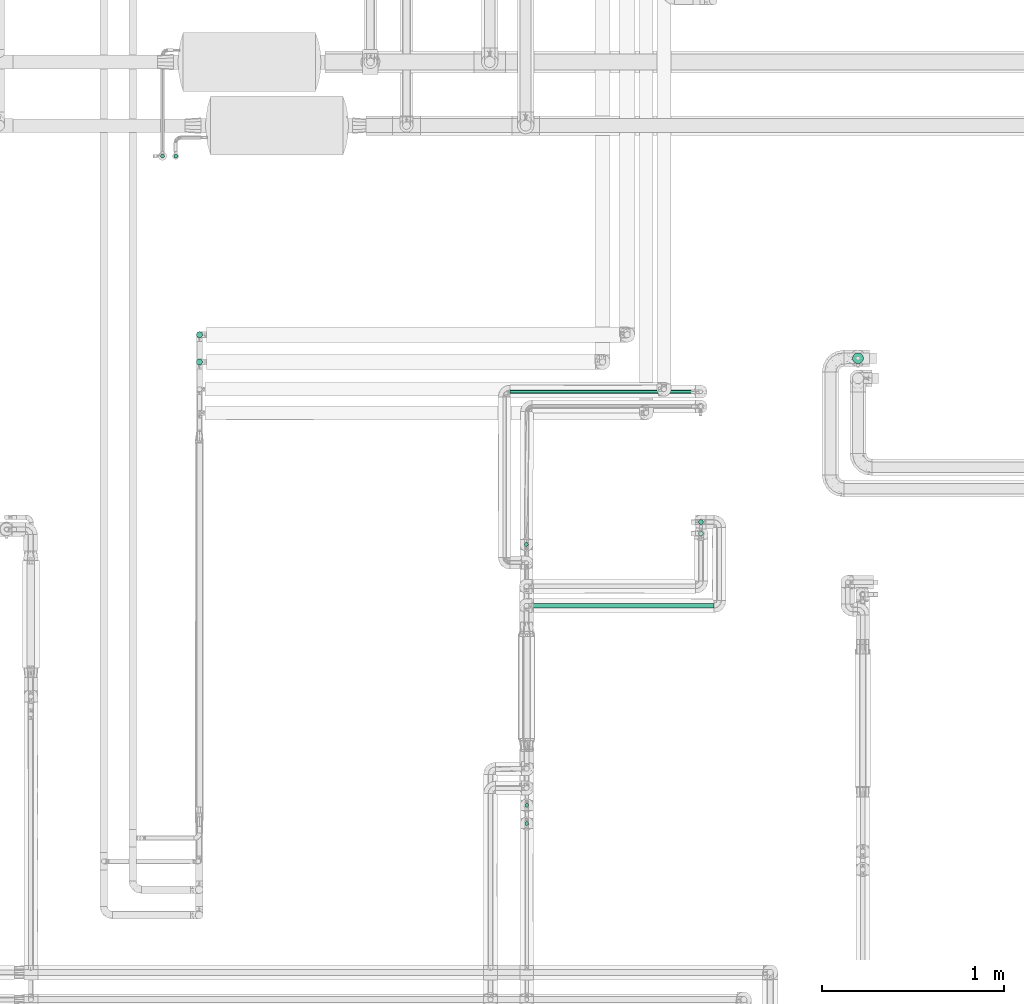
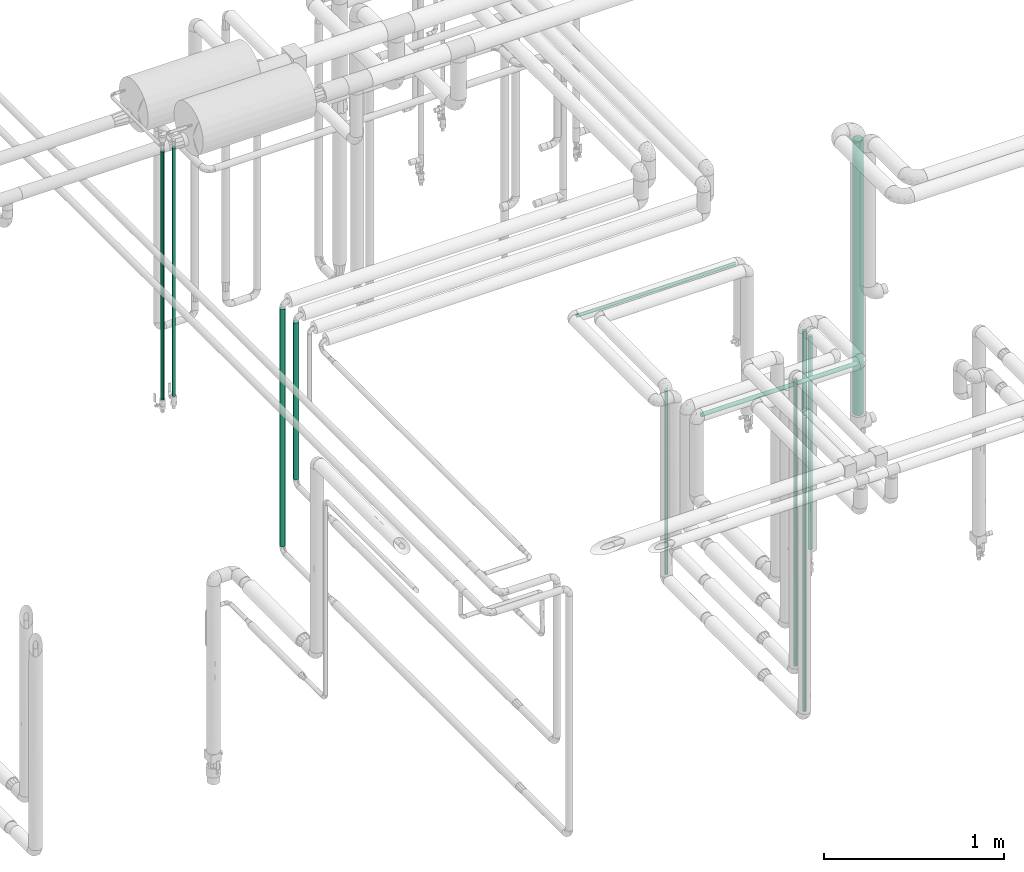
# One storey, part 520 of 827: 12 flow segments.
"""IFC2X3 building model written with IfcOpenShell, lengths in millimetres."""

from ifc_helpers import new_model, entity, si_unit, converted_unit, derived_unit, direction, frame, origin, origin_2d_with_axis, place, context, subcontext, project, spatial, circle, extrude, type_object, element, save


model = new_model("IFC2X3")

# Units and contexts
model_context = context("Model", 3, precision=0.01, world=origin(), true_north=direction((6.12303176911189e-17, 1.0)))
body_context = subcontext(model_context, "Body", "Model", "MODEL_VIEW")
ifc_project = project(units=[si_unit("LENGTHUNIT", "METRE", prefix="MILLI"), si_unit("AREAUNIT", "SQUARE_METRE"), si_unit("VOLUMEUNIT", "CUBIC_METRE"), converted_unit("PLANEANGLEUNIT", "DEGREE", entity("IfcRatioMeasure", 0.0174532925199433), si_unit("PLANEANGLEUNIT", "RADIAN"), dimensions=[0, 0, 0, 0, 0, 0, 0]), si_unit("MASSUNIT", "GRAM", prefix="KILO"), derived_unit("MASSDENSITYUNIT", [(si_unit("MASSUNIT", "GRAM", prefix="KILO"), 1), (si_unit("LENGTHUNIT", "METRE"), -3)]), derived_unit("MOMENTOFINERTIAUNIT", [(si_unit("LENGTHUNIT", "METRE"), 4)]), si_unit("TIMEUNIT", "SECOND"), si_unit("FREQUENCYUNIT", "HERTZ"), si_unit("THERMODYNAMICTEMPERATUREUNIT", "DEGREE_CELSIUS"), derived_unit("THERMALTRANSMITTANCEUNIT", [(si_unit("MASSUNIT", "GRAM", prefix="KILO"), 1), (si_unit("THERMODYNAMICTEMPERATUREUNIT", "KELVIN"), -1), (si_unit("TIMEUNIT", "SECOND"), -3)]), derived_unit("VOLUMETRICFLOWRATEUNIT", [(si_unit("LENGTHUNIT", "METRE"), 3), (si_unit("TIMEUNIT", "SECOND"), -1)]), derived_unit("MASSFLOWRATEUNIT", [(si_unit("MASSUNIT", "GRAM", prefix="KILO"), 1), (si_unit("TIMEUNIT", "SECOND"), -1)]), derived_unit("ROTATIONALFREQUENCYUNIT", [(si_unit("TIMEUNIT", "SECOND"), -1)]), si_unit("ELECTRICCURRENTUNIT", "AMPERE"), si_unit("ELECTRICVOLTAGEUNIT", "VOLT"), si_unit("POWERUNIT", "WATT"), si_unit("FORCEUNIT", "NEWTON", prefix="KILO"), si_unit("ILLUMINANCEUNIT", "LUX"), si_unit("LUMINOUSFLUXUNIT", "LUMEN"), si_unit("LUMINOUSINTENSITYUNIT", "CANDELA"), derived_unit("USERDEFINED", [(si_unit("MASSUNIT", "GRAM", prefix="KILO"), -1), (si_unit("LENGTHUNIT", "METRE"), -2), (si_unit("TIMEUNIT", "SECOND"), 3), (si_unit("LUMINOUSFLUXUNIT", "LUMEN"), 1)]), derived_unit("LINEARVELOCITYUNIT", [(si_unit("LENGTHUNIT", "METRE"), 1), (si_unit("TIMEUNIT", "SECOND"), -1)]), si_unit("PRESSUREUNIT", "PASCAL"), derived_unit("USERDEFINED", [(si_unit("LENGTHUNIT", "METRE"), -2), (si_unit("MASSUNIT", "GRAM", prefix="KILO"), 1), (si_unit("TIMEUNIT", "SECOND"), -2)]), derived_unit("LINEARFORCEUNIT", [(si_unit("MASSUNIT", "GRAM", prefix="KILO"), 1), (si_unit("LENGTHUNIT", "METRE"), 1), (si_unit("TIMEUNIT", "SECOND"), -2), (si_unit("LENGTHUNIT", "METRE"), -1)]), derived_unit("PLANARFORCEUNIT", [(si_unit("MASSUNIT", "GRAM", prefix="KILO"), 1), (si_unit("LENGTHUNIT", "METRE"), 1), (si_unit("TIMEUNIT", "SECOND"), -2), (si_unit("LENGTHUNIT", "METRE"), -2)])], contexts=[model_context])

# Site, building, storey
site_placement = place(None, origin())
site = spatial("IfcSite", under=ifc_project, at=site_placement, CompositionType="ELEMENT")
building_placement = place(site_placement, origin())
building = spatial("IfcBuilding", under=site, at=building_placement, CompositionType="ELEMENT")
storey_placement = place(building_placement, frame((0.0, 0.0, 28200.0)))
storey = spatial("IfcBuildingStorey", under=building, at=storey_placement, Name="08", CompositionType="ELEMENT", Elevation=28200.0)

# Flow segments
pipe_segment_type = type_object("IfcPipeSegmentType", PredefinedType="NOTDEFINED")
flow_segment_1_placement = place(storey_placement, frame((17955.82, 11744.52, 1885.0)))
element("IfcFlowSegment", 1, at=flow_segment_1_placement, inside=storey, type_object=pipe_segment_type, context=body_context, shape_type="SweptSolid", body=[
    extrude(circle(Radius=13.4, at=origin_2d_with_axis()), frame((0.0, 15.0, 15.0), z_axis=(1.0, 0.0, 0.0), x_axis=(0.0, -1.0, 0.0)), (0.0, 0.0, 1.0), 1001.2160714562),
])
flow_segment_2_placement = place(storey_placement, frame((17916.28, 10648.96, 873.75)))
element("IfcFlowSegment", 2, at=flow_segment_2_placement, inside=storey, type_object=pipe_segment_type, context=body_context, shape_type="SweptSolid", body=[
    extrude(circle(Radius=10.65, at=origin_2d_with_axis()), frame((12.25, 12.25, 0.0)), (0.0, 0.0, 1.0), 1948.38650320936),
])
flow_segment_3_placement = place(storey_placement, frame((17916.28, 10548.96, 627.35)))
element("IfcFlowSegment", 3, at=flow_segment_3_placement, inside=storey, type_object=pipe_segment_type, context=body_context, shape_type="SweptSolid", body=[
    extrude(circle(Radius=10.65, at=origin_2d_with_axis()), frame((12.25, 12.25, 0.0)), (0.0, 0.0, 1.0), 1996.37438235471),
])
flow_segment_4_placement = place(storey_placement, frame((18871.14, 12204.52, 779.1)))
element("IfcFlowSegment", 4, at=flow_segment_4_placement, inside=storey, type_object=pipe_segment_type, context=body_context, shape_type="SweptSolid", body=[
    extrude(circle(Radius=13.4, at=origin_2d_with_axis()), frame((15.0, 15.0, 0.0)), (0.0, 0.0, 1.0), 1091.80000000002),
])
flow_segment_5_placement = place(storey_placement, frame((18871.14, 12141.18, 426.5)))
element("IfcFlowSegment", 5, at=flow_segment_5_placement, inside=storey, type_object=pipe_segment_type, context=body_context, shape_type="SweptSolid", body=[
    extrude(circle(Radius=13.4, at=origin_2d_with_axis()), frame((15.0, 15.0, 0.0)), (0.0, 0.0, 1.0), 1444.40000000001),
])
flow_segment_6_placement = place(storey_placement, frame((19718.4, 13088.77, 461.5)))
element("IfcFlowSegment", 6, at=flow_segment_6_placement, inside=storey, type_object=pipe_segment_type, context=body_context, shape_type="SweptSolid", body=[
    extrude(circle(Radius=30.0, at=origin_2d_with_axis()), frame((31.6, 31.6, 0.0)), (0.0, 0.0, 1.0), 1862.5),
])
flow_segment_7_placement = place(storey_placement, frame((16109.71, 13231.65, 750.06)))
element("IfcFlowSegment", 7, at=flow_segment_7_placement, inside=storey, type_object=pipe_segment_type, context=body_context, shape_type="SweptSolid", body=[
    extrude(circle(Radius=16.75, at=origin_2d_with_axis()), frame((18.35, 18.35, 0.0)), (0.0, 0.0, 1.0), 1611.94077699676),
])
flow_segment_8_placement = place(storey_placement, frame((16109.71, 13081.65, 1296.33)))
element("IfcFlowSegment", 8, at=flow_segment_8_placement, inside=storey, type_object=pipe_segment_type, context=body_context, shape_type="SweptSolid", body=[
    extrude(circle(Radius=16.75, at=origin_2d_with_axis()), frame((18.35, 18.35, 0.0)), (0.0, 0.0, 1.0), 1065.66925284205),
])
flow_segment_9_placement = place(storey_placement, frame((15912.54, 14219.77, 1218.86)))
element("IfcFlowSegment", 9, at=flow_segment_9_placement, inside=storey, type_object=pipe_segment_type, context=body_context, shape_type="SweptSolid", body=[
    extrude(circle(Radius=10.65, at=origin_2d_with_axis()), frame((12.25, 12.25, 0.0)), (0.0, 0.0, 1.0), 1686.15038028327),
])
flow_segment_10_placement = place(storey_placement, frame((15985.01, 14219.77, 1218.86)))
element("IfcFlowSegment", 10, at=flow_segment_10_placement, inside=storey, type_object=pipe_segment_type, context=body_context, shape_type="SweptSolid", body=[
    extrude(circle(Radius=10.65, at=origin_2d_with_axis()), frame((12.25, 12.25, 0.0)), (0.0, 0.0, 1.0), 1686.00451925949),
])
flow_segment_11_placement = place(storey_placement, frame((17914.35, 12083.96, 627.45)))
element("IfcFlowSegment", 11, at=flow_segment_11_placement, inside=storey, type_object=pipe_segment_type, context=body_context, shape_type="SweptSolid", body=[
    extrude(circle(Radius=10.65, at=origin_2d_with_axis()), frame((12.25, 12.25, 0.0)), (0.0, 0.0, 1.0), 1244.55480092845),
])
flow_segment_12_placement = place(storey_placement, frame((17835.26, 12924.2, 1887.75)))
element("IfcFlowSegment", 12, at=flow_segment_12_placement, inside=storey, type_object=pipe_segment_type, context=body_context, shape_type="SweptSolid", body=[
    extrude(circle(Radius=10.65, at=origin_2d_with_axis()), frame((0.0, 12.25, 12.25), z_axis=(1.0, 0.0, 0.0), x_axis=(0.0, 1.0, 0.0)), (0.0, 0.0, 1.0), 1021.32326778375),
])

save(model, "model.ifc")
